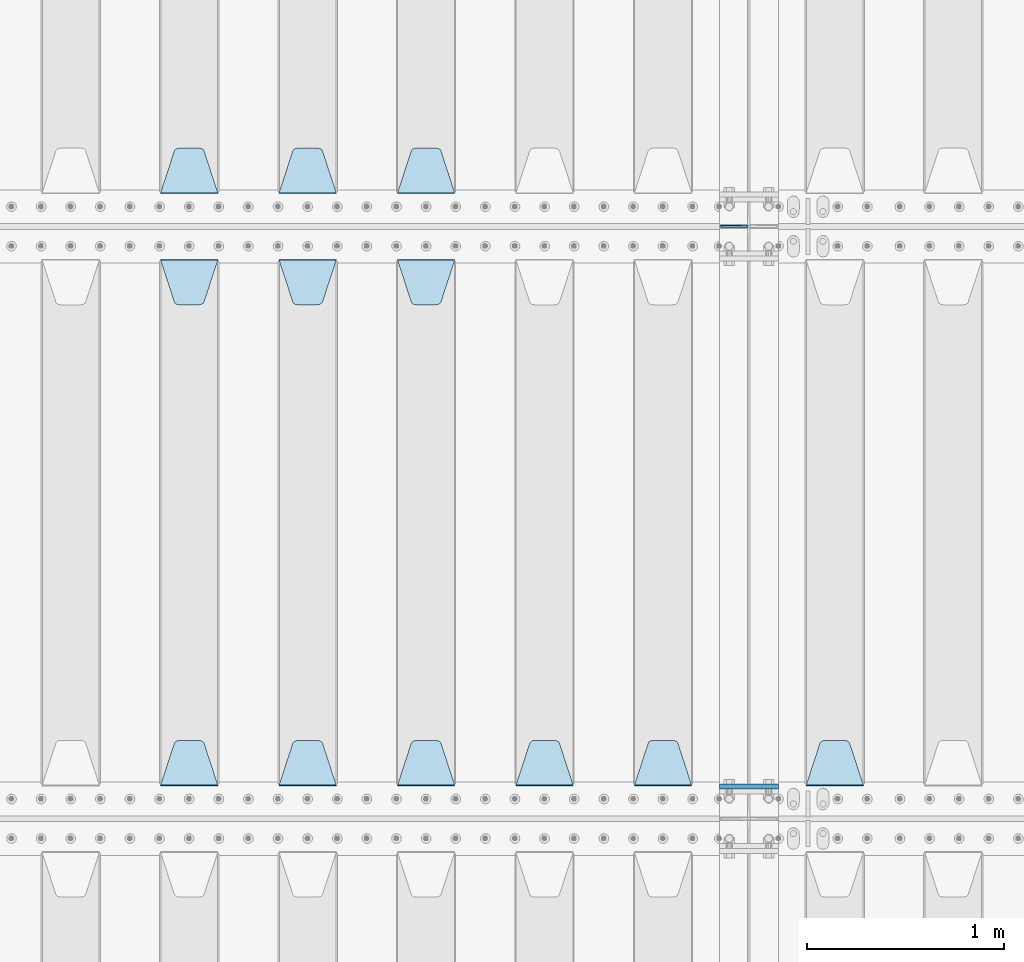
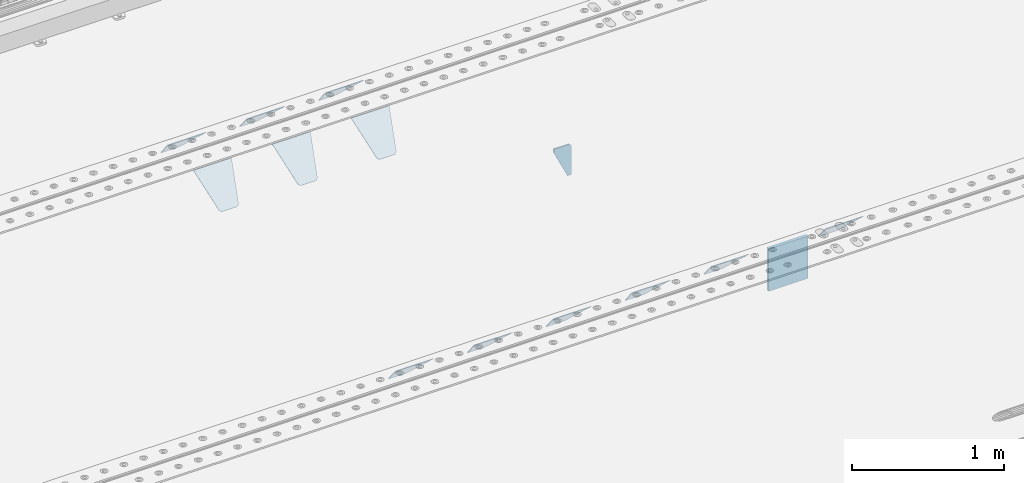
# One storey, part 227 of 270: 14 plates.
"""IFC2X3 building model written with IfcOpenShell, lengths in millimetres."""

from ifc_helpers import new_model, si_unit, frame, origin_with_axes, place, context, subcontext, project, spatial, faceted_brep, material, type_object, element, save


model = new_model("IFC2X3")

# Units and contexts
model_context = context("Model", 3, precision=1e-05, world=origin_with_axes())
body_context = subcontext(model_context, "Body", "Model", "MODEL_VIEW")
ifc_project = project(units=[si_unit("LENGTHUNIT", "METRE", prefix="MILLI"), si_unit("AREAUNIT", "SQUARE_METRE"), si_unit("VOLUMEUNIT", "CUBIC_METRE"), si_unit("MASSUNIT", "GRAM", prefix="KILO"), si_unit("TIMEUNIT", "SECOND"), si_unit("PLANEANGLEUNIT", "RADIAN"), si_unit("SOLIDANGLEUNIT", "STERADIAN"), si_unit("THERMODYNAMICTEMPERATUREUNIT", "DEGREE_CELSIUS"), si_unit("LUMINOUSINTENSITYUNIT", "LUMEN")], contexts=[model_context])

# Site, building, storey
site_placement = place(None, origin_with_axes())
site = spatial("IfcSite", under=ifc_project, at=site_placement, CompositionType="ELEMENT")
building_placement = place(site_placement, origin_with_axes())
building = spatial("IfcBuilding", under=site, at=building_placement, Name="Standard", CompositionType="ELEMENT")
storey_placement = place(building_placement, origin_with_axes())
storey = spatial("IfcBuildingStorey", under=building, at=storey_placement, Name="Undefined", CompositionType="ELEMENT", Elevation=0.0)

# Plates
ifc_material = material(Name="STEEL/S355N")
plate_type_1 = type_object("IfcPlateType", PredefinedType="NOTDEFINED")
plate_1_placement = place(storey_placement, frame((13885.0, -20837.5, -340.000000000044), z_axis=(0.0, 0.0, 1.0), x_axis=(1.0, 0.0, 0.0)))
element("IfcPlate", 1, at=plate_1_placement, inside=storey, type_object=plate_type_1, material=ifc_material, context=body_context, shape_type="Brep", body=[
    faceted_brep([(0.0, -12.5, 0.0), (9.27684595808387e-10, -12.5, 340.0), (9.27684595808387e-10, 12.5, 340.0), (0.0, 12.5, 0.0), (300.0, -12.5, 340.0), (300.0, 12.5, 340.0), (300.0, -12.5, 0.0), (300.0, 12.5, 0.0)], [[[0, 1, 2, 3]], [[1, 4, 5, 2]], [[4, 6, 7, 5]], [[6, 0, 3, 7]], [[5, 7, 3, 2]], [[6, 4, 1, 0]]]),
])
plate_type_2 = type_object("IfcPlateType", PredefinedType="NOTDEFINED")
plate_2_placement = place(storey_placement, frame((14028.5000000039, -18000.0000000457, -925.000018238937), z_axis=(0.0, 0.0, -1.0), x_axis=(-1.0, 0.0, 0.0)))
element("IfcPlate", 2, at=plate_2_placement, inside=storey, type_object=plate_type_2, material=ifc_material, context=body_context, shape_type="Brep", body=[
    faceted_brep([(0.0, -5.0, 27.0), (0.0, -5.0, 250.0), (0.0, 5.0, 250.0), (0.0, 5.0, 27.0), (30.0, -5.0, 250.0), (30.0, 5.0, 250.0), (135.0, -5.0, 30.0), (135.0, 5.0, 30.0), (135.0, -5.0, 0.0), (135.0, 5.0, 0.0), (27.0, -5.0, 0.0), (27.0, 5.0, 0.0), (22.3114992029932, -5.0, 0.410190668670339), (22.3114992029932, 5.0, 0.410190668670339), (17.7654561302061, -5.0, 1.62829923878053), (17.7654561302061, 5.0, 1.62829923878053), (13.5, -5.0, 3.6173140978201), (13.5, 5.0, 3.6173140978201), (9.64473453846404, -5.0, 6.31680003578754), (9.64473453846404, 5.0, 6.31680003578754), (6.31680003578731, -5.0, 9.64473453846347), (6.31680003578731, 5.0, 9.64473453846347), (3.61731409782078, -5.0, 13.5), (3.61731409782078, 5.0, 13.5), (1.62829923878053, -5.0, 17.765456130207), (1.62829923878053, 5.0, 17.765456130207), (0.410190668670111, -5.0, 22.3114992029929), (0.410190668670111, 5.0, 22.3114992029929)], [[[0, 1, 2, 3]], [[1, 4, 5, 2]], [[4, 6, 7, 5]], [[6, 8, 9, 7]], [[8, 10, 11, 9]], [[10, 12, 13, 11]], [[12, 14, 15, 13]], [[14, 16, 17, 15]], [[16, 18, 19, 17]], [[18, 20, 21, 19]], [[20, 22, 23, 21]], [[22, 24, 25, 23]], [[24, 26, 27, 25]], [[26, 0, 3, 27]], [[5, 7, 9, 11, 13, 15, 17, 19, 21, 23, 25, 27, 3, 2]], [[26, 24, 22, 20, 18, 16, 14, 12, 10, 8, 6, 4, 1, 0]]]),
])
plate_type_3 = type_object("IfcPlateType", PredefinedType="NOTDEFINED")
plate_3_placement = place(storey_placement, frame((12545.0, -17831.767766953, -1.76776695296758), z_axis=(0.0, 0.707106781186547, -0.707106781186548), x_axis=(-1.0, 0.0, 0.0)))
element("IfcPlate", 3, at=plate_3_placement, inside=storey, type_object=plate_type_3, material=ifc_material, context=body_context, shape_type="Brep", body=[
    faceted_brep([(0.0, -2.5, 0.0), (69.345504679477, -2.5, 300.171731424831), (69.345504679477, 2.5, 300.171731424831), (0.0, 2.5, 0.0), (70.9274061199576, -2.5, 304.8974424154), (70.9274061199576, 2.5, 304.8974424154), (73.3818627772307, -2.49999999999818, 309.234538108527), (73.3818627772307, 2.50000000000182, 309.234538108527), (76.6187032999551, -2.5, 313.023683126103), (76.6187032999551, 2.5, 313.023683126103), (80.5190132704993, -2.5, 316.125672595372), (80.5190132704993, 2.50000000000182, 316.125672595372), (84.9395038596849, -2.49999999999818, 318.426546230476), (84.9395038596849, 2.5, 318.426546230476), (89.7177759439219, -2.49999999999818, 319.841774983275), (89.7177759439219, 2.50000000000182, 319.841774983275), (94.678286292652, -2.5, 320.319366455078), (94.678286292652, 2.5, 320.319366455078), (195.321713707348, -2.5, 320.319366455078), (195.321713707348, 2.5, 320.319366455078), (200.282224056078, -2.49999999999818, 319.841774983275), (200.282224056078, 2.50000000000182, 319.841774983275), (205.060496140315, -2.5, 318.426546230476), (205.060496140315, 2.5, 318.426546230476), (209.480986729501, -2.5, 316.12567259537), (209.480986729501, 2.50000000000182, 316.12567259537), (213.381296700045, -2.5, 313.023683126103), (213.381296700045, 2.5, 313.023683126103), (216.618137222769, -2.49999999999818, 309.234538108525), (216.618137222769, 2.50000000000182, 309.234538108527), (219.072593880042, -2.49999999999818, 304.897442415398), (219.072593880042, 2.50000000000182, 304.897442415397), (220.654495320523, -2.5, 300.171731424831), (220.654495320523, 2.5, 300.171731424831), (290.0, -2.49999999999818, 0.0), (290.0, 2.5, 0.0)], [[[0, 1, 2, 3]], [[1, 4, 5, 2]], [[4, 6, 7, 5]], [[6, 8, 9, 7]], [[8, 10, 11, 9]], [[10, 12, 13, 11]], [[12, 14, 15, 13]], [[14, 16, 17, 15]], [[16, 18, 19, 17]], [[18, 20, 21, 19]], [[20, 22, 23, 21]], [[22, 24, 25, 23]], [[24, 26, 27, 25]], [[26, 28, 29, 27]], [[28, 30, 31, 29]], [[30, 32, 33, 31]], [[32, 34, 35, 33]], [[34, 0, 3, 35]], [[5, 7, 9, 11, 13, 15, 17, 19, 21, 23, 25, 27, 29, 31, 33, 35, 3, 2]], [[34, 32, 30, 28, 26, 24, 22, 20, 18, 16, 14, 12, 10, 8, 6, 4, 1, 0]]]),
])
plate_4_placement = place(storey_placement, frame((11945.0, -17831.767766953, -1.76776695296758), z_axis=(0.0, 0.707106781186547, -0.707106781186548), x_axis=(-1.0, 0.0, 0.0)))
element("IfcPlate", 4, at=plate_4_placement, inside=storey, type_object=plate_type_3, material=ifc_material, context=body_context, shape_type="Brep", body=[
    faceted_brep([(0.0, -2.5, 0.0), (69.345504679477, -2.5, 300.171731424831), (69.345504679477, 2.5, 300.171731424831), (0.0, 2.5, 0.0), (70.9274061199576, -2.5, 304.8974424154), (70.9274061199576, 2.5, 304.8974424154), (73.3818627772307, -2.49999999999818, 309.234538108527), (73.3818627772307, 2.50000000000182, 309.234538108527), (76.6187032999551, -2.5, 313.023683126103), (76.6187032999551, 2.5, 313.023683126103), (80.5190132704993, -2.5, 316.125672595372), (80.5190132704993, 2.50000000000182, 316.125672595372), (84.9395038596849, -2.49999999999818, 318.426546230476), (84.9395038596849, 2.5, 318.426546230476), (89.7177759439219, -2.49999999999818, 319.841774983275), (89.7177759439219, 2.50000000000182, 319.841774983275), (94.678286292652, -2.5, 320.319366455078), (94.678286292652, 2.5, 320.319366455078), (195.321713707348, -2.5, 320.319366455078), (195.321713707348, 2.5, 320.319366455078), (200.282224056078, -2.49999999999818, 319.841774983275), (200.282224056078, 2.50000000000182, 319.841774983275), (205.060496140315, -2.5, 318.426546230476), (205.060496140315, 2.5, 318.426546230476), (209.480986729501, -2.5, 316.12567259537), (209.480986729501, 2.50000000000182, 316.12567259537), (213.381296700045, -2.5, 313.023683126103), (213.381296700045, 2.5, 313.023683126103), (216.618137222769, -2.49999999999818, 309.234538108525), (216.618137222769, 2.50000000000182, 309.234538108527), (219.072593880042, -2.49999999999818, 304.897442415398), (219.072593880042, 2.50000000000182, 304.897442415397), (220.654495320523, -2.5, 300.171731424831), (220.654495320523, 2.5, 300.171731424831), (290.0, -2.49999999999818, 0.0), (290.0, 2.5, 0.0)], [[[0, 1, 2, 3]], [[1, 4, 5, 2]], [[4, 6, 7, 5]], [[6, 8, 9, 7]], [[8, 10, 11, 9]], [[10, 12, 13, 11]], [[12, 14, 15, 13]], [[14, 16, 17, 15]], [[16, 18, 19, 17]], [[18, 20, 21, 19]], [[20, 22, 23, 21]], [[22, 24, 25, 23]], [[24, 26, 27, 25]], [[26, 28, 29, 27]], [[28, 30, 31, 29]], [[30, 32, 33, 31]], [[32, 34, 35, 33]], [[34, 0, 3, 35]], [[5, 7, 9, 11, 13, 15, 17, 19, 21, 23, 25, 27, 29, 31, 33, 35, 3, 2]], [[34, 32, 30, 28, 26, 24, 22, 20, 18, 16, 14, 12, 10, 8, 6, 4, 1, 0]]]),
])
plate_5_placement = place(storey_placement, frame((11345.0, -17831.767766953, -1.76776695296758), z_axis=(0.0, 0.707106781186547, -0.707106781186548), x_axis=(-1.0, 0.0, 0.0)))
element("IfcPlate", 5, at=plate_5_placement, inside=storey, type_object=plate_type_3, material=ifc_material, context=body_context, shape_type="Brep", body=[
    faceted_brep([(0.0, -2.5, 0.0), (69.345504679477, -2.5, 300.171731424831), (69.345504679477, 2.5, 300.171731424831), (0.0, 2.5, 0.0), (70.9274061199576, -2.5, 304.8974424154), (70.9274061199576, 2.5, 304.8974424154), (73.3818627772307, -2.49999999999818, 309.234538108527), (73.3818627772307, 2.50000000000182, 309.234538108527), (76.6187032999551, -2.5, 313.023683126103), (76.6187032999551, 2.5, 313.023683126103), (80.5190132704993, -2.5, 316.125672595372), (80.5190132704993, 2.50000000000182, 316.125672595372), (84.9395038596849, -2.49999999999818, 318.426546230476), (84.9395038596849, 2.5, 318.426546230476), (89.7177759439219, -2.49999999999818, 319.841774983275), (89.7177759439219, 2.50000000000182, 319.841774983275), (94.678286292652, -2.5, 320.319366455078), (94.678286292652, 2.5, 320.319366455078), (195.321713707348, -2.5, 320.319366455078), (195.321713707348, 2.5, 320.319366455078), (200.282224056078, -2.49999999999818, 319.841774983275), (200.282224056078, 2.50000000000182, 319.841774983275), (205.060496140315, -2.5, 318.426546230476), (205.060496140315, 2.5, 318.426546230476), (209.480986729501, -2.5, 316.12567259537), (209.480986729501, 2.50000000000182, 316.12567259537), (213.381296700045, -2.5, 313.023683126103), (213.381296700045, 2.5, 313.023683126103), (216.618137222769, -2.49999999999818, 309.234538108525), (216.618137222769, 2.50000000000182, 309.234538108527), (219.072593880042, -2.49999999999818, 304.897442415398), (219.072593880042, 2.50000000000182, 304.897442415397), (220.654495320523, -2.5, 300.171731424831), (220.654495320523, 2.5, 300.171731424831), (290.0, -2.49999999999818, 0.0), (290.0, 2.5, 0.0)], [[[0, 1, 2, 3]], [[1, 4, 5, 2]], [[4, 6, 7, 5]], [[6, 8, 9, 7]], [[8, 10, 11, 9]], [[10, 12, 13, 11]], [[12, 14, 15, 13]], [[14, 16, 17, 15]], [[16, 18, 19, 17]], [[18, 20, 21, 19]], [[20, 22, 23, 21]], [[22, 24, 25, 23]], [[24, 26, 27, 25]], [[26, 28, 29, 27]], [[28, 30, 31, 29]], [[30, 32, 33, 31]], [[32, 34, 35, 33]], [[34, 0, 3, 35]], [[5, 7, 9, 11, 13, 15, 17, 19, 21, 23, 25, 27, 29, 31, 33, 35, 3, 2]], [[34, 32, 30, 28, 26, 24, 22, 20, 18, 16, 14, 12, 10, 8, 6, 4, 1, 0]]]),
])
plate_6_placement = place(storey_placement, frame((14615.0, -20831.767766953, -1.76776695296758), z_axis=(0.0, 0.707106781186547, -0.707106781186548), x_axis=(-1.0, 0.0, 0.0)))
element("IfcPlate", 6, at=plate_6_placement, inside=storey, type_object=plate_type_3, material=ifc_material, context=body_context, shape_type="Brep", body=[
    faceted_brep([(0.0, -2.5, 0.0), (69.345504679477, -2.5, 300.171731424831), (69.345504679477, 2.5, 300.171731424831), (0.0, 2.5, 0.0), (70.9274061199576, -2.5, 304.8974424154), (70.9274061199576, 2.5, 304.8974424154), (73.3818627772307, -2.49999999999818, 309.234538108527), (73.3818627772307, 2.50000000000182, 309.234538108527), (76.6187032999551, -2.5, 313.023683126103), (76.6187032999551, 2.5, 313.023683126103), (80.5190132704993, -2.5, 316.125672595372), (80.5190132704993, 2.50000000000182, 316.125672595372), (84.9395038596849, -2.49999999999818, 318.426546230476), (84.9395038596849, 2.5, 318.426546230476), (89.7177759439219, -2.49999999999818, 319.841774983275), (89.7177759439219, 2.50000000000182, 319.841774983275), (94.678286292652, -2.5, 320.319366455078), (94.678286292652, 2.5, 320.319366455078), (195.321713707348, -2.5, 320.319366455078), (195.321713707348, 2.5, 320.319366455078), (200.282224056078, -2.49999999999818, 319.841774983275), (200.282224056078, 2.50000000000182, 319.841774983275), (205.060496140315, -2.5, 318.426546230476), (205.060496140315, 2.5, 318.426546230476), (209.480986729501, -2.5, 316.12567259537), (209.480986729501, 2.50000000000182, 316.12567259537), (213.381296700045, -2.5, 313.023683126103), (213.381296700045, 2.5, 313.023683126103), (216.618137222769, -2.49999999999818, 309.234538108525), (216.618137222769, 2.50000000000182, 309.234538108527), (219.072593880042, -2.49999999999818, 304.897442415398), (219.072593880042, 2.50000000000182, 304.897442415397), (220.654495320523, -2.5, 300.171731424831), (220.654495320523, 2.5, 300.171731424831), (290.0, -2.49999999999818, 0.0), (290.0, 2.5, 0.0)], [[[0, 1, 2, 3]], [[1, 4, 5, 2]], [[4, 6, 7, 5]], [[6, 8, 9, 7]], [[8, 10, 11, 9]], [[10, 12, 13, 11]], [[12, 14, 15, 13]], [[14, 16, 17, 15]], [[16, 18, 19, 17]], [[18, 20, 21, 19]], [[20, 22, 23, 21]], [[22, 24, 25, 23]], [[24, 26, 27, 25]], [[26, 28, 29, 27]], [[28, 30, 31, 29]], [[30, 32, 33, 31]], [[32, 34, 35, 33]], [[34, 0, 3, 35]], [[5, 7, 9, 11, 13, 15, 17, 19, 21, 23, 25, 27, 29, 31, 33, 35, 3, 2]], [[34, 32, 30, 28, 26, 24, 22, 20, 18, 16, 14, 12, 10, 8, 6, 4, 1, 0]]]),
])
plate_7_placement = place(storey_placement, frame((13745.0, -20831.767766953, -1.76776695296758), z_axis=(0.0, 0.707106781186547, -0.707106781186548), x_axis=(-1.0, 0.0, 0.0)))
element("IfcPlate", 7, at=plate_7_placement, inside=storey, type_object=plate_type_3, material=ifc_material, context=body_context, shape_type="Brep", body=[
    faceted_brep([(0.0, -2.5, 0.0), (69.345504679477, -2.5, 300.171731424831), (69.345504679477, 2.5, 300.171731424831), (0.0, 2.5, 0.0), (70.9274061199576, -2.5, 304.8974424154), (70.9274061199576, 2.5, 304.8974424154), (73.3818627772307, -2.49999999999818, 309.234538108527), (73.3818627772307, 2.50000000000182, 309.234538108527), (76.6187032999551, -2.5, 313.023683126103), (76.6187032999551, 2.5, 313.023683126103), (80.5190132704993, -2.5, 316.125672595372), (80.5190132704993, 2.50000000000182, 316.125672595372), (84.9395038596849, -2.49999999999818, 318.426546230476), (84.9395038596849, 2.5, 318.426546230476), (89.7177759439219, -2.49999999999818, 319.841774983275), (89.7177759439219, 2.50000000000182, 319.841774983275), (94.678286292652, -2.5, 320.319366455078), (94.678286292652, 2.5, 320.319366455078), (195.321713707348, -2.5, 320.319366455078), (195.321713707348, 2.5, 320.319366455078), (200.282224056078, -2.49999999999818, 319.841774983275), (200.282224056078, 2.50000000000182, 319.841774983275), (205.060496140315, -2.5, 318.426546230476), (205.060496140315, 2.5, 318.426546230476), (209.480986729501, -2.5, 316.12567259537), (209.480986729501, 2.50000000000182, 316.12567259537), (213.381296700045, -2.5, 313.023683126103), (213.381296700045, 2.5, 313.023683126103), (216.618137222769, -2.49999999999818, 309.234538108525), (216.618137222769, 2.50000000000182, 309.234538108527), (219.072593880042, -2.49999999999818, 304.897442415398), (219.072593880042, 2.50000000000182, 304.897442415397), (220.654495320523, -2.5, 300.171731424831), (220.654495320523, 2.5, 300.171731424831), (290.0, -2.49999999999818, 0.0), (290.0, 2.5, 0.0)], [[[0, 1, 2, 3]], [[1, 4, 5, 2]], [[4, 6, 7, 5]], [[6, 8, 9, 7]], [[8, 10, 11, 9]], [[10, 12, 13, 11]], [[12, 14, 15, 13]], [[14, 16, 17, 15]], [[16, 18, 19, 17]], [[18, 20, 21, 19]], [[20, 22, 23, 21]], [[22, 24, 25, 23]], [[24, 26, 27, 25]], [[26, 28, 29, 27]], [[28, 30, 31, 29]], [[30, 32, 33, 31]], [[32, 34, 35, 33]], [[34, 0, 3, 35]], [[5, 7, 9, 11, 13, 15, 17, 19, 21, 23, 25, 27, 29, 31, 33, 35, 3, 2]], [[34, 32, 30, 28, 26, 24, 22, 20, 18, 16, 14, 12, 10, 8, 6, 4, 1, 0]]]),
])
plate_8_placement = place(storey_placement, frame((13145.0, -20831.767766953, -1.76776695296758), z_axis=(0.0, 0.707106781186547, -0.707106781186548), x_axis=(-1.0, 0.0, 0.0)))
element("IfcPlate", 8, at=plate_8_placement, inside=storey, type_object=plate_type_3, material=ifc_material, context=body_context, shape_type="Brep", body=[
    faceted_brep([(0.0, -2.5, 0.0), (69.345504679477, -2.5, 300.171731424831), (69.345504679477, 2.5, 300.171731424831), (0.0, 2.5, 0.0), (70.9274061199576, -2.5, 304.8974424154), (70.9274061199576, 2.5, 304.8974424154), (73.3818627772307, -2.49999999999818, 309.234538108527), (73.3818627772307, 2.50000000000182, 309.234538108527), (76.6187032999551, -2.5, 313.023683126103), (76.6187032999551, 2.5, 313.023683126103), (80.5190132704993, -2.5, 316.125672595372), (80.5190132704993, 2.50000000000182, 316.125672595372), (84.9395038596849, -2.49999999999818, 318.426546230476), (84.9395038596849, 2.5, 318.426546230476), (89.7177759439219, -2.49999999999818, 319.841774983275), (89.7177759439219, 2.50000000000182, 319.841774983275), (94.678286292652, -2.5, 320.319366455078), (94.678286292652, 2.5, 320.319366455078), (195.321713707348, -2.5, 320.319366455078), (195.321713707348, 2.5, 320.319366455078), (200.282224056078, -2.49999999999818, 319.841774983275), (200.282224056078, 2.50000000000182, 319.841774983275), (205.060496140315, -2.5, 318.426546230476), (205.060496140315, 2.5, 318.426546230476), (209.480986729501, -2.5, 316.12567259537), (209.480986729501, 2.50000000000182, 316.12567259537), (213.381296700045, -2.5, 313.023683126103), (213.381296700045, 2.5, 313.023683126103), (216.618137222769, -2.49999999999818, 309.234538108525), (216.618137222769, 2.50000000000182, 309.234538108527), (219.072593880042, -2.49999999999818, 304.897442415398), (219.072593880042, 2.50000000000182, 304.897442415397), (220.654495320523, -2.5, 300.171731424831), (220.654495320523, 2.5, 300.171731424831), (290.0, -2.49999999999818, 0.0), (290.0, 2.5, 0.0)], [[[0, 1, 2, 3]], [[1, 4, 5, 2]], [[4, 6, 7, 5]], [[6, 8, 9, 7]], [[8, 10, 11, 9]], [[10, 12, 13, 11]], [[12, 14, 15, 13]], [[14, 16, 17, 15]], [[16, 18, 19, 17]], [[18, 20, 21, 19]], [[20, 22, 23, 21]], [[22, 24, 25, 23]], [[24, 26, 27, 25]], [[26, 28, 29, 27]], [[28, 30, 31, 29]], [[30, 32, 33, 31]], [[32, 34, 35, 33]], [[34, 0, 3, 35]], [[5, 7, 9, 11, 13, 15, 17, 19, 21, 23, 25, 27, 29, 31, 33, 35, 3, 2]], [[34, 32, 30, 28, 26, 24, 22, 20, 18, 16, 14, 12, 10, 8, 6, 4, 1, 0]]]),
])
plate_9_placement = place(storey_placement, frame((12255.0, -18168.232233044, -1.76776695296576), z_axis=(0.0, -0.707106781186548, -0.707106781186547), x_axis=(1.0, 0.0, 0.0)))
element("IfcPlate", 9, at=plate_9_placement, inside=storey, type_object=plate_type_3, material=ifc_material, context=body_context, shape_type="Brep", body=[
    faceted_brep([(0.0, -2.5, 0.0), (69.345504679477, -2.5, 300.171731424831), (69.345504679477, 2.5, 300.171731424831), (0.0, 2.5, 0.0), (70.9274061199576, -2.5, 304.8974424154), (70.9274061199576, 2.5, 304.8974424154), (73.3818627772307, -2.49999999999818, 309.234538108527), (73.3818627772307, 2.50000000000182, 309.234538108527), (76.6187032999551, -2.5, 313.023683126103), (76.6187032999551, 2.5, 313.023683126103), (80.5190132704993, -2.5, 316.125672595372), (80.5190132704993, 2.50000000000182, 316.125672595372), (84.9395038596849, -2.49999999999818, 318.426546230476), (84.9395038596849, 2.5, 318.426546230476), (89.7177759439219, -2.49999999999818, 319.841774983275), (89.7177759439219, 2.50000000000182, 319.841774983275), (94.678286292652, -2.5, 320.319366455078), (94.678286292652, 2.5, 320.319366455078), (195.321713707348, -2.5, 320.319366455078), (195.321713707348, 2.5, 320.319366455078), (200.282224056078, -2.49999999999818, 319.841774983275), (200.282224056078, 2.50000000000182, 319.841774983275), (205.060496140315, -2.5, 318.426546230476), (205.060496140315, 2.5, 318.426546230476), (209.480986729501, -2.5, 316.12567259537), (209.480986729501, 2.50000000000182, 316.12567259537), (213.381296700045, -2.5, 313.023683126103), (213.381296700045, 2.5, 313.023683126103), (216.618137222769, -2.49999999999818, 309.234538108525), (216.618137222769, 2.50000000000182, 309.234538108527), (219.072593880042, -2.49999999999818, 304.897442415398), (219.072593880042, 2.50000000000182, 304.897442415397), (220.654495320523, -2.5, 300.171731424831), (220.654495320523, 2.5, 300.171731424831), (290.0, -2.49999999999818, 0.0), (290.0, 2.5, 0.0)], [[[0, 1, 2, 3]], [[1, 4, 5, 2]], [[4, 6, 7, 5]], [[6, 8, 9, 7]], [[8, 10, 11, 9]], [[10, 12, 13, 11]], [[12, 14, 15, 13]], [[14, 16, 17, 15]], [[16, 18, 19, 17]], [[18, 20, 21, 19]], [[20, 22, 23, 21]], [[22, 24, 25, 23]], [[24, 26, 27, 25]], [[26, 28, 29, 27]], [[28, 30, 31, 29]], [[30, 32, 33, 31]], [[32, 34, 35, 33]], [[34, 0, 3, 35]], [[5, 7, 9, 11, 13, 15, 17, 19, 21, 23, 25, 27, 29, 31, 33, 35, 3, 2]], [[34, 32, 30, 28, 26, 24, 22, 20, 18, 16, 14, 12, 10, 8, 6, 4, 1, 0]]]),
])
plate_10_placement = place(storey_placement, frame((12545.0, -20831.767766953, -1.76776695296758), z_axis=(0.0, 0.707106781186547, -0.707106781186548), x_axis=(-1.0, 0.0, 0.0)))
element("IfcPlate", 10, at=plate_10_placement, inside=storey, type_object=plate_type_3, material=ifc_material, context=body_context, shape_type="Brep", body=[
    faceted_brep([(0.0, -2.5, 0.0), (69.345504679477, -2.5, 300.171731424831), (69.345504679477, 2.5, 300.171731424831), (0.0, 2.5, 0.0), (70.9274061199576, -2.5, 304.8974424154), (70.9274061199576, 2.5, 304.8974424154), (73.3818627772307, -2.49999999999818, 309.234538108527), (73.3818627772307, 2.50000000000182, 309.234538108527), (76.6187032999551, -2.5, 313.023683126103), (76.6187032999551, 2.5, 313.023683126103), (80.5190132704993, -2.5, 316.125672595372), (80.5190132704993, 2.50000000000182, 316.125672595372), (84.9395038596849, -2.49999999999818, 318.426546230476), (84.9395038596849, 2.5, 318.426546230476), (89.7177759439219, -2.49999999999818, 319.841774983275), (89.7177759439219, 2.50000000000182, 319.841774983275), (94.678286292652, -2.5, 320.319366455078), (94.678286292652, 2.5, 320.319366455078), (195.321713707348, -2.5, 320.319366455078), (195.321713707348, 2.5, 320.319366455078), (200.282224056078, -2.49999999999818, 319.841774983275), (200.282224056078, 2.50000000000182, 319.841774983275), (205.060496140315, -2.5, 318.426546230476), (205.060496140315, 2.5, 318.426546230476), (209.480986729501, -2.5, 316.12567259537), (209.480986729501, 2.50000000000182, 316.12567259537), (213.381296700045, -2.5, 313.023683126103), (213.381296700045, 2.5, 313.023683126103), (216.618137222769, -2.49999999999818, 309.234538108525), (216.618137222769, 2.50000000000182, 309.234538108527), (219.072593880042, -2.49999999999818, 304.897442415398), (219.072593880042, 2.50000000000182, 304.897442415397), (220.654495320523, -2.5, 300.171731424831), (220.654495320523, 2.5, 300.171731424831), (290.0, -2.49999999999818, 0.0), (290.0, 2.5, 0.0)], [[[0, 1, 2, 3]], [[1, 4, 5, 2]], [[4, 6, 7, 5]], [[6, 8, 9, 7]], [[8, 10, 11, 9]], [[10, 12, 13, 11]], [[12, 14, 15, 13]], [[14, 16, 17, 15]], [[16, 18, 19, 17]], [[18, 20, 21, 19]], [[20, 22, 23, 21]], [[22, 24, 25, 23]], [[24, 26, 27, 25]], [[26, 28, 29, 27]], [[28, 30, 31, 29]], [[30, 32, 33, 31]], [[32, 34, 35, 33]], [[34, 0, 3, 35]], [[5, 7, 9, 11, 13, 15, 17, 19, 21, 23, 25, 27, 29, 31, 33, 35, 3, 2]], [[34, 32, 30, 28, 26, 24, 22, 20, 18, 16, 14, 12, 10, 8, 6, 4, 1, 0]]]),
])
plate_11_placement = place(storey_placement, frame((11655.0, -18168.232233044, -1.76776695296576), z_axis=(0.0, -0.707106781186548, -0.707106781186547), x_axis=(1.0, 0.0, 0.0)))
element("IfcPlate", 11, at=plate_11_placement, inside=storey, type_object=plate_type_3, material=ifc_material, context=body_context, shape_type="Brep", body=[
    faceted_brep([(0.0, -2.5, 0.0), (69.345504679477, -2.5, 300.171731424831), (69.345504679477, 2.5, 300.171731424831), (0.0, 2.5, 0.0), (70.9274061199576, -2.5, 304.8974424154), (70.9274061199576, 2.5, 304.8974424154), (73.3818627772307, -2.49999999999818, 309.234538108527), (73.3818627772307, 2.50000000000182, 309.234538108527), (76.6187032999551, -2.5, 313.023683126103), (76.6187032999551, 2.5, 313.023683126103), (80.5190132704993, -2.5, 316.125672595372), (80.5190132704993, 2.50000000000182, 316.125672595372), (84.9395038596849, -2.49999999999818, 318.426546230476), (84.9395038596849, 2.5, 318.426546230476), (89.7177759439219, -2.49999999999818, 319.841774983275), (89.7177759439219, 2.50000000000182, 319.841774983275), (94.678286292652, -2.5, 320.319366455078), (94.678286292652, 2.5, 320.319366455078), (195.321713707348, -2.5, 320.319366455078), (195.321713707348, 2.5, 320.319366455078), (200.282224056078, -2.49999999999818, 319.841774983275), (200.282224056078, 2.50000000000182, 319.841774983275), (205.060496140315, -2.5, 318.426546230476), (205.060496140315, 2.5, 318.426546230476), (209.480986729501, -2.5, 316.12567259537), (209.480986729501, 2.50000000000182, 316.12567259537), (213.381296700045, -2.5, 313.023683126103), (213.381296700045, 2.5, 313.023683126103), (216.618137222769, -2.49999999999818, 309.234538108525), (216.618137222769, 2.50000000000182, 309.234538108527), (219.072593880042, -2.49999999999818, 304.897442415398), (219.072593880042, 2.50000000000182, 304.897442415397), (220.654495320523, -2.5, 300.171731424831), (220.654495320523, 2.5, 300.171731424831), (290.0, -2.49999999999818, 0.0), (290.0, 2.5, 0.0)], [[[0, 1, 2, 3]], [[1, 4, 5, 2]], [[4, 6, 7, 5]], [[6, 8, 9, 7]], [[8, 10, 11, 9]], [[10, 12, 13, 11]], [[12, 14, 15, 13]], [[14, 16, 17, 15]], [[16, 18, 19, 17]], [[18, 20, 21, 19]], [[20, 22, 23, 21]], [[22, 24, 25, 23]], [[24, 26, 27, 25]], [[26, 28, 29, 27]], [[28, 30, 31, 29]], [[30, 32, 33, 31]], [[32, 34, 35, 33]], [[34, 0, 3, 35]], [[5, 7, 9, 11, 13, 15, 17, 19, 21, 23, 25, 27, 29, 31, 33, 35, 3, 2]], [[34, 32, 30, 28, 26, 24, 22, 20, 18, 16, 14, 12, 10, 8, 6, 4, 1, 0]]]),
])
plate_12_placement = place(storey_placement, frame((11945.0, -20831.767766953, -1.76776695296758), z_axis=(0.0, 0.707106781186547, -0.707106781186548), x_axis=(-1.0, 0.0, 0.0)))
element("IfcPlate", 12, at=plate_12_placement, inside=storey, type_object=plate_type_3, material=ifc_material, context=body_context, shape_type="Brep", body=[
    faceted_brep([(0.0, -2.5, 0.0), (69.345504679477, -2.5, 300.171731424831), (69.345504679477, 2.5, 300.171731424831), (0.0, 2.5, 0.0), (70.9274061199576, -2.5, 304.8974424154), (70.9274061199576, 2.5, 304.8974424154), (73.3818627772307, -2.49999999999818, 309.234538108527), (73.3818627772307, 2.50000000000182, 309.234538108527), (76.6187032999551, -2.5, 313.023683126103), (76.6187032999551, 2.5, 313.023683126103), (80.5190132704993, -2.5, 316.125672595372), (80.5190132704993, 2.50000000000182, 316.125672595372), (84.9395038596849, -2.49999999999818, 318.426546230476), (84.9395038596849, 2.5, 318.426546230476), (89.7177759439219, -2.49999999999818, 319.841774983275), (89.7177759439219, 2.50000000000182, 319.841774983275), (94.678286292652, -2.5, 320.319366455078), (94.678286292652, 2.5, 320.319366455078), (195.321713707348, -2.5, 320.319366455078), (195.321713707348, 2.5, 320.319366455078), (200.282224056078, -2.49999999999818, 319.841774983275), (200.282224056078, 2.50000000000182, 319.841774983275), (205.060496140315, -2.5, 318.426546230476), (205.060496140315, 2.5, 318.426546230476), (209.480986729501, -2.5, 316.12567259537), (209.480986729501, 2.50000000000182, 316.12567259537), (213.381296700045, -2.5, 313.023683126103), (213.381296700045, 2.5, 313.023683126103), (216.618137222769, -2.49999999999818, 309.234538108525), (216.618137222769, 2.50000000000182, 309.234538108527), (219.072593880042, -2.49999999999818, 304.897442415398), (219.072593880042, 2.50000000000182, 304.897442415397), (220.654495320523, -2.5, 300.171731424831), (220.654495320523, 2.5, 300.171731424831), (290.0, -2.49999999999818, 0.0), (290.0, 2.5, 0.0)], [[[0, 1, 2, 3]], [[1, 4, 5, 2]], [[4, 6, 7, 5]], [[6, 8, 9, 7]], [[8, 10, 11, 9]], [[10, 12, 13, 11]], [[12, 14, 15, 13]], [[14, 16, 17, 15]], [[16, 18, 19, 17]], [[18, 20, 21, 19]], [[20, 22, 23, 21]], [[22, 24, 25, 23]], [[24, 26, 27, 25]], [[26, 28, 29, 27]], [[28, 30, 31, 29]], [[30, 32, 33, 31]], [[32, 34, 35, 33]], [[34, 0, 3, 35]], [[5, 7, 9, 11, 13, 15, 17, 19, 21, 23, 25, 27, 29, 31, 33, 35, 3, 2]], [[34, 32, 30, 28, 26, 24, 22, 20, 18, 16, 14, 12, 10, 8, 6, 4, 1, 0]]]),
])
plate_13_placement = place(storey_placement, frame((11055.0, -18168.232233044, -1.76776695296576), z_axis=(0.0, -0.707106781186548, -0.707106781186547), x_axis=(1.0, 0.0, 0.0)))
element("IfcPlate", 13, at=plate_13_placement, inside=storey, type_object=plate_type_3, material=ifc_material, context=body_context, shape_type="Brep", body=[
    faceted_brep([(0.0, -2.5, 0.0), (69.345504679477, -2.5, 300.171731424831), (69.345504679477, 2.5, 300.171731424831), (0.0, 2.5, 0.0), (70.9274061199576, -2.5, 304.8974424154), (70.9274061199576, 2.5, 304.8974424154), (73.3818627772307, -2.49999999999818, 309.234538108527), (73.3818627772307, 2.50000000000182, 309.234538108527), (76.6187032999551, -2.5, 313.023683126103), (76.6187032999551, 2.5, 313.023683126103), (80.5190132704993, -2.5, 316.125672595372), (80.5190132704993, 2.50000000000182, 316.125672595372), (84.9395038596849, -2.49999999999818, 318.426546230476), (84.9395038596849, 2.5, 318.426546230476), (89.7177759439219, -2.49999999999818, 319.841774983275), (89.7177759439219, 2.50000000000182, 319.841774983275), (94.678286292652, -2.5, 320.319366455078), (94.678286292652, 2.5, 320.319366455078), (195.321713707348, -2.5, 320.319366455078), (195.321713707348, 2.5, 320.319366455078), (200.282224056078, -2.49999999999818, 319.841774983275), (200.282224056078, 2.50000000000182, 319.841774983275), (205.060496140315, -2.5, 318.426546230476), (205.060496140315, 2.5, 318.426546230476), (209.480986729501, -2.5, 316.12567259537), (209.480986729501, 2.50000000000182, 316.12567259537), (213.381296700045, -2.5, 313.023683126103), (213.381296700045, 2.5, 313.023683126103), (216.618137222769, -2.49999999999818, 309.234538108525), (216.618137222769, 2.50000000000182, 309.234538108527), (219.072593880042, -2.49999999999818, 304.897442415398), (219.072593880042, 2.50000000000182, 304.897442415397), (220.654495320523, -2.5, 300.171731424831), (220.654495320523, 2.5, 300.171731424831), (290.0, -2.49999999999818, 0.0), (290.0, 2.5, 0.0)], [[[0, 1, 2, 3]], [[1, 4, 5, 2]], [[4, 6, 7, 5]], [[6, 8, 9, 7]], [[8, 10, 11, 9]], [[10, 12, 13, 11]], [[12, 14, 15, 13]], [[14, 16, 17, 15]], [[16, 18, 19, 17]], [[18, 20, 21, 19]], [[20, 22, 23, 21]], [[22, 24, 25, 23]], [[24, 26, 27, 25]], [[26, 28, 29, 27]], [[28, 30, 31, 29]], [[30, 32, 33, 31]], [[32, 34, 35, 33]], [[34, 0, 3, 35]], [[5, 7, 9, 11, 13, 15, 17, 19, 21, 23, 25, 27, 29, 31, 33, 35, 3, 2]], [[34, 32, 30, 28, 26, 24, 22, 20, 18, 16, 14, 12, 10, 8, 6, 4, 1, 0]]]),
])
plate_14_placement = place(storey_placement, frame((11345.0, -20831.767766953, -1.76776695296758), z_axis=(0.0, 0.707106781186547, -0.707106781186548), x_axis=(-1.0, 0.0, 0.0)))
element("IfcPlate", 14, at=plate_14_placement, inside=storey, type_object=plate_type_3, material=ifc_material, context=body_context, shape_type="Brep", body=[
    faceted_brep([(0.0, -2.5, 0.0), (69.345504679477, -2.5, 300.171731424831), (69.345504679477, 2.5, 300.171731424831), (0.0, 2.5, 0.0), (70.9274061199576, -2.5, 304.8974424154), (70.9274061199576, 2.5, 304.8974424154), (73.3818627772307, -2.49999999999818, 309.234538108527), (73.3818627772307, 2.50000000000182, 309.234538108527), (76.6187032999551, -2.5, 313.023683126103), (76.6187032999551, 2.5, 313.023683126103), (80.5190132704993, -2.5, 316.125672595372), (80.5190132704993, 2.50000000000182, 316.125672595372), (84.9395038596849, -2.49999999999818, 318.426546230476), (84.9395038596849, 2.5, 318.426546230476), (89.7177759439219, -2.49999999999818, 319.841774983275), (89.7177759439219, 2.50000000000182, 319.841774983275), (94.678286292652, -2.5, 320.319366455078), (94.678286292652, 2.5, 320.319366455078), (195.321713707348, -2.5, 320.319366455078), (195.321713707348, 2.5, 320.319366455078), (200.282224056078, -2.49999999999818, 319.841774983275), (200.282224056078, 2.50000000000182, 319.841774983275), (205.060496140315, -2.5, 318.426546230476), (205.060496140315, 2.5, 318.426546230476), (209.480986729501, -2.5, 316.12567259537), (209.480986729501, 2.50000000000182, 316.12567259537), (213.381296700045, -2.5, 313.023683126103), (213.381296700045, 2.5, 313.023683126103), (216.618137222769, -2.49999999999818, 309.234538108525), (216.618137222769, 2.50000000000182, 309.234538108527), (219.072593880042, -2.49999999999818, 304.897442415398), (219.072593880042, 2.50000000000182, 304.897442415397), (220.654495320523, -2.5, 300.171731424831), (220.654495320523, 2.5, 300.171731424831), (290.0, -2.49999999999818, 0.0), (290.0, 2.5, 0.0)], [[[0, 1, 2, 3]], [[1, 4, 5, 2]], [[4, 6, 7, 5]], [[6, 8, 9, 7]], [[8, 10, 11, 9]], [[10, 12, 13, 11]], [[12, 14, 15, 13]], [[14, 16, 17, 15]], [[16, 18, 19, 17]], [[18, 20, 21, 19]], [[20, 22, 23, 21]], [[22, 24, 25, 23]], [[24, 26, 27, 25]], [[26, 28, 29, 27]], [[28, 30, 31, 29]], [[30, 32, 33, 31]], [[32, 34, 35, 33]], [[34, 0, 3, 35]], [[5, 7, 9, 11, 13, 15, 17, 19, 21, 23, 25, 27, 29, 31, 33, 35, 3, 2]], [[34, 32, 30, 28, 26, 24, 22, 20, 18, 16, 14, 12, 10, 8, 6, 4, 1, 0]]]),
])

save(model, "model.ifc")
